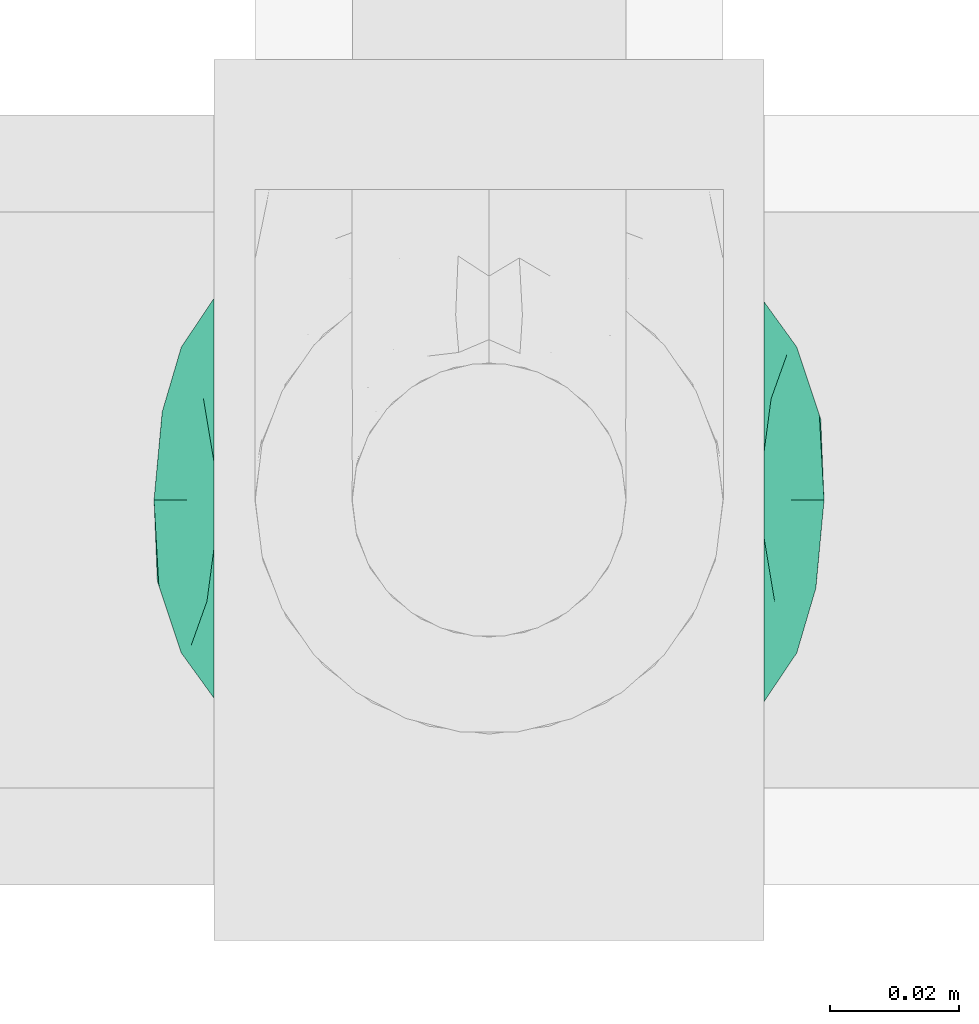
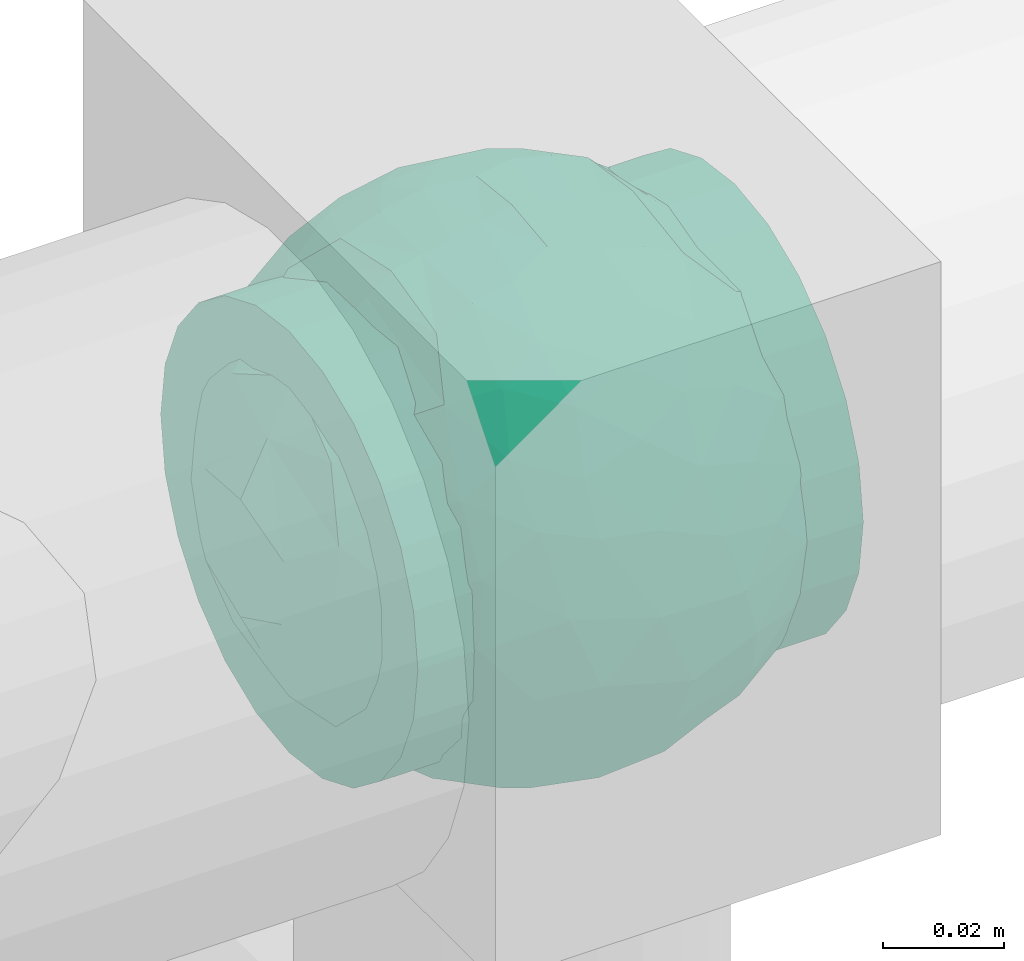
# One storey, part 572 of 827: 1 flow fitting.
"""IFC2X3 building model written with IfcOpenShell, lengths in millimetres."""

from ifc_helpers import new_model, entity, si_unit, converted_unit, derived_unit, direction, frame, origin, place, context, subcontext, project, spatial, faceted_brep, source, transform, mapped, material, material_list, type_object, type_shapes, element, save


model = new_model("IFC2X3")

# Units and contexts
model_context = context("Model", 3, precision=0.01, world=origin(), true_north=direction((6.12303176911189e-17, 1.0)))
body_context = subcontext(model_context, "Body", "Model", "MODEL_VIEW")
ifc_project = project(units=[si_unit("LENGTHUNIT", "METRE", prefix="MILLI"), si_unit("AREAUNIT", "SQUARE_METRE"), si_unit("VOLUMEUNIT", "CUBIC_METRE"), converted_unit("PLANEANGLEUNIT", "DEGREE", entity("IfcRatioMeasure", 0.0174532925199433), si_unit("PLANEANGLEUNIT", "RADIAN"), dimensions=[0, 0, 0, 0, 0, 0, 0]), si_unit("MASSUNIT", "GRAM", prefix="KILO"), derived_unit("MASSDENSITYUNIT", [(si_unit("MASSUNIT", "GRAM", prefix="KILO"), 1), (si_unit("LENGTHUNIT", "METRE"), -3)]), derived_unit("MOMENTOFINERTIAUNIT", [(si_unit("LENGTHUNIT", "METRE"), 4)]), si_unit("TIMEUNIT", "SECOND"), si_unit("FREQUENCYUNIT", "HERTZ"), si_unit("THERMODYNAMICTEMPERATUREUNIT", "DEGREE_CELSIUS"), derived_unit("THERMALTRANSMITTANCEUNIT", [(si_unit("MASSUNIT", "GRAM", prefix="KILO"), 1), (si_unit("THERMODYNAMICTEMPERATUREUNIT", "KELVIN"), -1), (si_unit("TIMEUNIT", "SECOND"), -3)]), derived_unit("VOLUMETRICFLOWRATEUNIT", [(si_unit("LENGTHUNIT", "METRE"), 3), (si_unit("TIMEUNIT", "SECOND"), -1)]), derived_unit("MASSFLOWRATEUNIT", [(si_unit("MASSUNIT", "GRAM", prefix="KILO"), 1), (si_unit("TIMEUNIT", "SECOND"), -1)]), derived_unit("ROTATIONALFREQUENCYUNIT", [(si_unit("TIMEUNIT", "SECOND"), -1)]), si_unit("ELECTRICCURRENTUNIT", "AMPERE"), si_unit("ELECTRICVOLTAGEUNIT", "VOLT"), si_unit("POWERUNIT", "WATT"), si_unit("FORCEUNIT", "NEWTON", prefix="KILO"), si_unit("ILLUMINANCEUNIT", "LUX"), si_unit("LUMINOUSFLUXUNIT", "LUMEN"), si_unit("LUMINOUSINTENSITYUNIT", "CANDELA"), derived_unit("USERDEFINED", [(si_unit("MASSUNIT", "GRAM", prefix="KILO"), -1), (si_unit("LENGTHUNIT", "METRE"), -2), (si_unit("TIMEUNIT", "SECOND"), 3), (si_unit("LUMINOUSFLUXUNIT", "LUMEN"), 1)]), derived_unit("LINEARVELOCITYUNIT", [(si_unit("LENGTHUNIT", "METRE"), 1), (si_unit("TIMEUNIT", "SECOND"), -1)]), si_unit("PRESSUREUNIT", "PASCAL"), derived_unit("USERDEFINED", [(si_unit("LENGTHUNIT", "METRE"), -2), (si_unit("MASSUNIT", "GRAM", prefix="KILO"), 1), (si_unit("TIMEUNIT", "SECOND"), -2)]), derived_unit("LINEARFORCEUNIT", [(si_unit("MASSUNIT", "GRAM", prefix="KILO"), 1), (si_unit("LENGTHUNIT", "METRE"), 1), (si_unit("TIMEUNIT", "SECOND"), -2), (si_unit("LENGTHUNIT", "METRE"), -1)]), derived_unit("PLANARFORCEUNIT", [(si_unit("MASSUNIT", "GRAM", prefix="KILO"), 1), (si_unit("LENGTHUNIT", "METRE"), 1), (si_unit("TIMEUNIT", "SECOND"), -2), (si_unit("LENGTHUNIT", "METRE"), -2)])], contexts=[model_context])

# Site, building, storey
site_placement = place(None, origin())
site = spatial("IfcSite", under=ifc_project, at=site_placement, CompositionType="ELEMENT")
building_placement = place(site_placement, origin())
building = spatial("IfcBuilding", under=site, at=building_placement, CompositionType="ELEMENT")
storey_placement = place(building_placement, frame((0.0, 0.0, 28200.0)))
storey = spatial("IfcBuildingStorey", under=building, at=storey_placement, Name="08", CompositionType="ELEMENT", Elevation=28200.0)

# Flow fitting
ifc_material_1 = material()
ifc_material_2 = material(Name="ADSK_")
ifc_material_list = material_list([ifc_material_1, ifc_material_2])
pipe_fitting_type = type_object("IfcPipeFittingType", Name="ADSK_1", PredefinedType="NOTDEFINED", material=ifc_material_list)
shared_shape = source(origin(), body_context, "Body", "Brep", [
    faceted_brep([(-42.5, 0.0, -42.5), (-42.5, -11.0, -41.05), (-42.5, -21.25, -36.81), (-42.5, -30.05, -30.05), (-42.5, -36.81, -21.25), (-42.5, -41.05, -11.0), (-42.5, -41.78, -5.5), (-42.5, -42.5, 0.0), (-42.5, -41.78, 5.5), (-42.5, -41.05, 11.0), (-42.5, -36.81, 21.25), (-42.5, -30.05, 30.05), (-42.5, -21.25, 36.81), (-42.5, -11.0, 41.05), (-42.5, 0.0, 42.5), (-42.5, 11.0, 41.05), (-42.5, 21.25, 36.81), (-42.5, 30.05, 30.05), (-42.5, 36.81, 21.25), (-42.5, 41.05, 11.0), (-42.5, 42.5, 0.0), (-42.5, 41.05, -11.0), (-42.5, 36.81, -21.25), (-42.5, 30.05, -30.05), (-42.5, 21.25, -36.81), (-42.5, 11.0, -41.05), (42.5, 11.0, -41.05), (42.5, 21.25, -36.81), (42.5, 30.05, -30.05), (42.5, 36.81, -21.25), (42.5, 41.05, -11.0), (42.5, 42.5, 0.0), (42.5, 41.05, 11.0), (42.5, 36.81, 21.25), (42.5, 30.05, 30.05), (42.5, 21.25, 36.81), (42.5, 11.0, 41.05), (42.5, 0.0, 42.5), (42.5, -11.0, 41.05), (42.5, -21.25, 36.81), (42.5, -30.05, 30.05), (42.5, -36.81, 21.25), (42.5, -41.05, 11.0), (42.5, -41.78, 5.5), (42.5, -42.5, 0.0), (42.5, -41.78, -5.5), (42.5, -41.05, -11.0), (42.5, -36.81, -21.25), (42.5, -30.05, -30.05), (42.5, -21.25, -36.81), (42.5, -11.0, -41.05), (42.5, 0.0, -42.5), (17.36, -42.02, 6.38), (18.5, -42.5, 0.0), (-18.5, -42.5, 0.0), (14.15, -40.8, 11.92), (3.25, -38.4, 18.21), (9.29, -39.37, 16.0), (6.27, -38.89, 17.11), (-17.36, -42.02, 6.38), (-17.93, -42.26, 3.19), (-14.16, -40.8, 11.91), (-9.29, -39.37, 16.0), (-6.27, -38.89, 17.1), (-3.25, -38.4, 18.21), (0.0, -38.4, 18.21), (17.93, -42.26, 3.19), (17.36, -42.02, -6.38), (3.25, -38.4, -18.21), (-17.36, -42.02, -6.38), (-17.93, -42.26, -3.19), (9.29, -39.37, -16.0), (6.27, -38.89, -17.11), (14.15, -40.8, -11.92), (17.93, -42.26, -3.19), (-3.25, -38.4, -18.21), (-6.27, -38.89, -17.1), (-9.29, -39.37, -16.0), (0.0, -38.4, -18.21), (-14.16, -40.8, -11.91), (17.87, -47.5, -4.79), (18.5, -47.5, 0.0), (17.87, -47.5, 4.79), (16.02, -47.5, 9.25), (13.08, -47.5, 13.08), (9.25, -47.5, 16.02), (4.79, -47.5, 17.87), (0.0, -47.5, 18.5), (-4.79, -47.5, 17.87), (-9.25, -47.5, 16.02), (-13.08, -47.5, 13.08), (-16.02, -47.5, 9.25), (-17.87, -47.5, 4.79), (-18.5, -47.5, 0.0), (-17.87, -47.5, -4.79), (-16.02, -47.5, -9.25), (-13.08, -47.5, -13.08), (-9.25, -47.5, -16.02), (-4.79, -47.5, -17.87), (0.0, -47.5, -18.5), (4.79, -47.5, -17.87), (9.25, -47.5, -16.02), (13.08, -47.5, -13.08), (16.02, -47.5, -9.25)], [[[0, 1, 2, 3, 4, 5, 6, 7, 8, 9, 10, 11, 12, 13, 14, 15, 16, 17, 18, 19, 20, 21, 22, 23, 24, 25]], [[26, 27, 28, 29, 30, 31, 32, 33, 34, 35, 36, 37, 38, 39, 40, 41, 42, 43, 44, 45, 46, 47, 48, 49, 50, 51]], [[43, 42, 52]], [[53, 44, 43]], [[7, 54, 8]], [[42, 55, 52]], [[41, 40, 56]], [[55, 42, 57]], [[41, 56, 58, 57]], [[40, 11, 56]], [[57, 42, 41]], [[59, 9, 8]], [[8, 54, 60, 59]], [[59, 61, 9]], [[10, 62, 63, 64]], [[10, 9, 62]], [[10, 64, 11]], [[62, 9, 61]], [[11, 64, 65, 56]], [[43, 52, 66, 53]], [[40, 39, 12, 11]], [[14, 13, 38, 37]], [[13, 12, 39, 38]], [[15, 14, 37, 36]], [[33, 32, 19, 18]], [[17, 16, 35, 34]], [[18, 17, 34, 33]], [[36, 35, 16, 15]], [[20, 19, 32, 31]], [[20, 31, 30, 21]], [[29, 28, 23, 22]], [[21, 30, 29, 22]], [[51, 50, 1, 0]], [[25, 24, 27, 26]], [[51, 0, 25, 26]], [[28, 27, 24, 23]], [[2, 1, 50, 49]], [[67, 46, 45]], [[49, 48, 3, 2]], [[48, 47, 68]], [[6, 69, 70, 54]], [[47, 71, 72, 68]], [[47, 46, 71]], [[48, 68, 3]], [[44, 53, 45]], [[6, 54, 7]], [[67, 73, 46]], [[45, 53, 74, 67]], [[46, 73, 71]], [[4, 75, 76, 77]], [[4, 3, 75]], [[77, 5, 4]], [[3, 68, 78, 75]], [[79, 69, 5]], [[69, 6, 5]], [[79, 5, 77]], [[80, 81, 82, 83, 84, 85, 86, 87, 88, 89, 90, 91, 92, 93, 94, 95, 96, 97, 98, 99, 100, 101, 102, 103]], [[92, 60, 93]], [[61, 91, 90]], [[92, 91, 59]], [[90, 89, 62]], [[92, 59, 60]], [[60, 54, 93]], [[59, 91, 61]], [[66, 52, 82]], [[88, 64, 63]], [[62, 61, 90]], [[87, 56, 65, 64]], [[85, 58, 86]], [[87, 64, 88]], [[56, 87, 86]], [[58, 85, 57]], [[55, 84, 83]], [[85, 84, 57]], [[52, 83, 82]], [[84, 55, 57]], [[56, 86, 58]], [[63, 62, 89]], [[81, 66, 82]], [[52, 55, 83]], [[66, 81, 53]], [[63, 89, 88]], [[80, 74, 81]], [[73, 103, 102]], [[80, 103, 67]], [[102, 101, 71]], [[80, 67, 74]], [[74, 53, 81]], [[67, 103, 73]], [[70, 69, 94]], [[100, 68, 72]], [[71, 73, 102]], [[99, 75, 78, 68]], [[97, 76, 98]], [[99, 68, 100]], [[75, 99, 98]], [[76, 97, 77]], [[79, 96, 95]], [[97, 96, 77]], [[69, 95, 94]], [[96, 79, 77]], [[75, 98, 76]], [[72, 71, 101]], [[93, 70, 94]], [[69, 79, 95]], [[70, 93, 54]], [[72, 101, 100]]]),
    faceted_brep([(46.38, -14.47, -21.49), (47.57, 0.0, -23.65), (51.28, -5.95, -12.54), (17.7, 5.66, -49.77), (12.28, -8.85, -50.92), (2.15, 2.87, -53.0), (-8.3, -38.19, -35.98), (-18.28, -40.66, -28.89), (-11.82, -29.03, -42.89), (40.06, -7.7, -34.03), (11.3, 28.17, -43.6), (20.41, 21.08, -44.28), (11.07, 18.92, -48.39), (51.79, 0.0, 0.0), (51.07, 6.92, -12.89), (-39.8, 12.92, -32.73), (-33.3, 12.91, -39.33), (-40.47, 3.74, -34.21), (51.79, 11.82, 0.0), (10.27, 45.23, -25.91), (18.57, 40.35, -29.15), (8.87, 37.57, -36.49), (39.0, 21.71, -28.82), (29.98, 13.37, -41.77), (30.17, 25.51, -35.52), (39.42, 8.24, -34.65), (32.29, 40.49, 0.0), (36.91, 36.81, 0.0), (35.0, 34.14, -20.79), (27.67, 44.18, 0.0), (-47.57, 0.0, -23.65), (-38.16, -9.26, -35.78), (-45.37, -12.95, -24.42), (5.76, -51.81, 0.0), (0.0, -51.83, -11.64), (8.06, -50.4, -14.75), (36.12, -33.63, -19.67), (42.51, -27.89, -15.42), (32.29, -40.49, 0.0), (-50.53, -9.19, -13.6), (46.66, -22.47, 0.0), (-50.52, 9.22, -13.61), (-46.66, 22.47, 0.0), (-44.16, 25.02, -15.71), (-39.0, 21.71, -28.82), (-45.35, 12.92, -24.47), (-0.05, -47.47, -23.85), (46.06, 13.95, -22.51), (-10.28, -45.49, -25.44), (3.12, -40.7, -34.0), (11.24, -34.38, -38.91), (18.57, -40.35, -29.15), (31.25, -15.19, -40.19), (31.09, 0.0, -43.08), (-36.91, 36.81, 0.0), (-37.82, 32.8, -17.79), (17.29, 49.18, 0.0), (16.36, 48.2, -15.2), (11.53, 50.49, 0.0), (-23.47, 44.9, -15.98), (-17.29, 49.18, 0.0), (-16.36, 48.2, -15.2), (-37.8, -32.81, -17.81), (-36.91, -36.81, 0.0), (-44.14, -25.04, -15.71), (-22.53, -31.78, -36.12), (-23.47, -44.9, -15.98), (-30.38, -38.01, -21.33), (29.72, -28.61, -33.48), (28.22, -39.05, -22.38), (-4.99, -13.62, -51.1), (-3.95, -23.43, -47.52), (0.0, -31.72, -42.62), (-9.33, 24.94, -45.97), (-11.38, 12.91, -50.26), (-20.38, 21.05, -44.31), (20.41, -21.08, -44.28), (10.92, -45.96, -24.31), (-17.29, -49.18, 0.0), (-16.38, -48.27, -14.96), (-11.53, -50.49, 0.0), (-23.05, -47.86, 0.0), (-27.67, -44.18, 0.0), (-32.29, -40.49, 0.0), (-28.59, -12.44, -43.01), (-30.36, -23.94, -36.43), (-15.25, 0.59, -50.89), (21.67, 31.55, -36.84), (27.5, 37.78, -25.27), (-2.02, 40.69, -34.1), (-0.05, 47.47, -23.85), (-10.14, 45.33, -25.77), (-10.75, 35.1, -38.4), (-18.28, 40.66, -28.89), (-30.38, 38.01, -21.33), (-32.29, 40.49, 0.0), (-27.67, 44.18, 0.0), (-23.05, 47.86, 0.0), (0.98, 18.06, -49.95), (0.0, 31.72, -42.62), (-30.21, 25.12, -35.76), (23.46, -45.39, -14.56), (0.0, -53.13, 0.0), (-8.48, 50.24, -15.03), (-11.53, 50.49, 0.0), (-5.76, 51.81, 0.0), (-41.53, -33.12, 0.0), (-39.0, -21.71, -28.82), (-21.3, 31.75, -36.88), (51.79, -11.82, 0.0), (39.0, -21.71, -28.82), (41.53, -33.12, 0.0), (46.66, 22.47, 0.0), (43.6, 26.01, -15.64), (22.77, -10.48, -46.84), (21.09, -32.2, -36.62), (27.67, -44.18, 0.0), (8.79, -24.03, -46.56), (-20.38, -21.05, -44.31), (-18.66, -10.27, -48.67), (-31.09, 0.0, -43.08), (-23.67, 8.98, -46.71), (23.05, -47.86, 0.0), (-8.24, -50.28, -15.03), (23.47, 45.01, -15.67), (23.05, 47.86, 0.0), (8.44, 50.21, -15.18), (5.76, 51.81, 0.0), (-46.66, -22.47, 0.0), (-41.53, 33.12, 0.0), (-51.79, 11.82, 0.0), (-51.79, -11.82, 0.0), (-51.79, 0.0, 0.0), (0.0, 53.12, 0.0), (0.0, 51.81, -11.73), (-5.76, -51.81, 0.0), (17.29, -49.18, 0.0), (11.53, -50.49, 0.0), (41.53, 33.12, 0.0), (36.91, -36.81, 0.0), (-46.38, -14.47, 21.49), (-47.57, 0.0, 23.65), (-51.28, -5.95, 12.54), (-17.7, 5.66, 49.77), (-12.28, -8.85, 50.92), (-2.15, 2.87, 53.0), (8.3, -38.19, 35.98), (18.28, -40.66, 28.89), (11.82, -29.03, 42.89), (-40.06, -7.7, 34.03), (-11.3, 28.17, 43.6), (-20.41, 21.08, 44.28), (-11.07, 18.92, 48.39), (-51.07, 6.92, 12.89), (39.8, 12.92, 32.73), (33.3, 12.91, 39.33), (40.47, 3.74, 34.21), (-10.27, 45.23, 25.91), (-18.57, 40.35, 29.15), (-8.87, 37.57, 36.49), (-39.0, 21.71, 28.82), (-29.98, 13.37, 41.77), (-30.17, 25.51, 35.52), (-39.42, 8.24, 34.65), (-35.0, 34.14, 20.79), (47.57, 0.0, 23.65), (38.16, -9.26, 35.78), (45.37, -12.95, 24.42), (0.0, -51.83, 11.64), (-8.06, -50.4, 14.75), (-36.12, -33.63, 19.67), (-42.51, -27.89, 15.42), (50.53, -9.19, 13.6), (50.52, 9.22, 13.61), (44.16, 25.02, 15.71), (39.0, 21.71, 28.82), (45.35, 12.92, 24.47), (0.05, -47.47, 23.85), (-46.06, 13.95, 22.51), (10.28, -45.49, 25.44), (-3.12, -40.7, 34.0), (-11.24, -34.38, 38.91), (-18.57, -40.35, 29.15), (-31.25, -15.19, 40.19), (-31.09, 0.0, 43.08), (37.82, 32.8, 17.79), (-16.36, 48.2, 15.2), (23.47, 44.9, 15.98), (16.36, 48.2, 15.2), (37.8, -32.81, 17.81), (44.14, -25.04, 15.71), (22.53, -31.78, 36.12), (23.47, -44.9, 15.98), (30.38, -38.01, 21.33), (-29.72, -28.61, 33.48), (-28.22, -39.05, 22.38), (4.99, -13.62, 51.1), (3.95, -23.43, 47.52), (0.0, -31.72, 42.62), (9.33, 24.94, 45.97), (11.38, 12.91, 50.26), (20.38, 21.05, 44.31), (-20.41, -21.08, 44.28), (-10.92, -45.96, 24.31), (16.38, -48.27, 14.96), (28.59, -12.44, 43.01), (30.36, -23.94, 36.43), (15.25, 0.59, 50.89), (-21.67, 31.55, 36.84), (-27.5, 37.78, 25.27), (2.02, 40.69, 34.1), (0.05, 47.47, 23.85), (10.14, 45.33, 25.77), (10.75, 35.1, 38.4), (18.28, 40.66, 28.89), (30.38, 38.01, 21.33), (-0.98, 18.06, 49.95), (0.0, 31.72, 42.62), (30.21, 25.12, 35.76), (-23.46, -45.39, 14.56), (8.48, 50.24, 15.03), (39.0, -21.71, 28.82), (21.3, 31.75, 36.88), (-39.0, -21.71, 28.82), (-43.6, 26.01, 15.64), (-22.77, -10.48, 46.84), (-21.09, -32.2, 36.62), (-8.79, -24.03, 46.56), (20.38, -21.05, 44.31), (18.66, -10.27, 48.67), (31.09, 0.0, 43.08), (23.67, 8.98, 46.71), (8.24, -50.28, 15.03), (-23.47, 45.01, 15.67), (-8.44, 50.21, 15.18), (0.0, 51.81, 11.73)], [[[0, 1, 2]], [[3, 4, 5]], [[6, 7, 8]], [[1, 0, 9]], [[10, 11, 12]], [[13, 2, 14]], [[15, 16, 17]], [[14, 18, 13]], [[19, 20, 21]], [[22, 23, 24]], [[1, 9, 25]], [[26, 27, 28, 29]], [[30, 31, 32]], [[33, 34, 35]], [[36, 37, 38]], [[32, 39, 30]], [[2, 40, 0]], [[23, 22, 25]], [[41, 42, 43]], [[44, 15, 45]], [[46, 35, 34]], [[25, 22, 47]], [[31, 30, 17]], [[48, 49, 46]], [[50, 51, 49]], [[52, 53, 9]], [[43, 54, 55]], [[56, 57, 58]], [[59, 60, 61]], [[62, 63, 64]], [[8, 7, 65]], [[7, 66, 67]], [[68, 36, 69]], [[70, 5, 4]], [[8, 71, 72]], [[73, 74, 75]], [[68, 76, 52]], [[77, 46, 49]], [[78, 79, 80]], [[7, 6, 48]], [[67, 81, 82, 83]], [[84, 85, 31]], [[85, 65, 67]], [[70, 86, 5]], [[23, 3, 11]], [[21, 87, 10]], [[21, 20, 87]], [[28, 24, 88]], [[19, 89, 90]], [[91, 90, 89]], [[91, 92, 93]], [[94, 95, 96, 97]], [[98, 99, 10]], [[100, 16, 44]], [[77, 51, 101]], [[33, 102, 34]], [[103, 91, 61]], [[93, 59, 61]], [[104, 105, 103]], [[106, 64, 63]], [[107, 31, 85]], [[100, 94, 108]], [[108, 93, 92]], [[43, 55, 44]], [[0, 40, 37]], [[2, 13, 109]], [[2, 1, 14]], [[110, 9, 0]], [[2, 109, 40]], [[37, 40, 111]], [[47, 14, 1]], [[112, 14, 47]], [[113, 112, 47]], [[112, 18, 14]], [[47, 22, 113]], [[52, 9, 110]], [[53, 25, 9]], [[25, 47, 1]], [[23, 25, 53]], [[68, 52, 110]], [[76, 4, 114]], [[51, 115, 69]], [[50, 115, 51]], [[110, 36, 68]], [[3, 23, 53]], [[23, 11, 24]], [[52, 76, 114]], [[98, 12, 5]], [[11, 87, 24]], [[24, 28, 22]], [[87, 88, 24]], [[36, 116, 69]], [[28, 27, 113]], [[114, 3, 53]], [[76, 115, 117]], [[70, 4, 117]], [[118, 84, 119]], [[119, 70, 118]], [[120, 16, 121]], [[37, 36, 110]], [[116, 36, 38]], [[116, 122, 69]], [[34, 123, 46]], [[10, 87, 11]], [[87, 20, 88]], [[12, 98, 10]], [[10, 99, 21]], [[74, 5, 86]], [[73, 75, 108]], [[124, 56, 125]], [[124, 29, 88]], [[89, 21, 99]], [[21, 89, 19]], [[92, 89, 99]], [[89, 92, 91]], [[126, 127, 58]], [[88, 29, 28]], [[20, 57, 124]], [[88, 20, 124]], [[57, 20, 19]], [[73, 92, 99]], [[92, 73, 108]], [[99, 98, 73]], [[74, 86, 121]], [[73, 98, 74]], [[5, 74, 98]], [[100, 108, 75]], [[94, 93, 108]], [[86, 120, 121]], [[100, 44, 55]], [[75, 16, 100]], [[17, 16, 120]], [[31, 17, 120]], [[17, 30, 45]], [[84, 31, 120]], [[31, 107, 32]], [[41, 45, 30]], [[43, 44, 45]], [[107, 64, 32]], [[39, 64, 128]], [[30, 39, 41]], [[129, 43, 42]], [[41, 130, 42]], [[43, 45, 41]], [[62, 83, 63]], [[95, 94, 55]], [[100, 55, 94]], [[64, 107, 62]], [[131, 39, 128]], [[64, 106, 128]], [[85, 62, 107]], [[67, 83, 62]], [[39, 32, 64]], [[130, 41, 132]], [[59, 97, 60]], [[133, 127, 134]], [[59, 94, 97]], [[104, 61, 60]], [[94, 59, 93]], [[126, 134, 127]], [[126, 58, 57]], [[19, 90, 126]], [[134, 105, 133]], [[126, 90, 134]], [[103, 90, 91]], [[105, 134, 103]], [[90, 103, 134]], [[119, 120, 86]], [[84, 118, 85]], [[65, 85, 118]], [[62, 85, 67]], [[8, 65, 118]], [[67, 65, 7]], [[71, 118, 70]], [[8, 72, 6]], [[49, 6, 72]], [[6, 49, 48]], [[50, 49, 72]], [[77, 49, 51]], [[101, 69, 122]], [[123, 34, 135]], [[101, 122, 136]], [[137, 77, 136]], [[78, 81, 66]], [[7, 79, 66]], [[67, 66, 81]], [[79, 7, 48]], [[35, 137, 33]], [[123, 80, 79]], [[135, 34, 102]], [[35, 46, 77]], [[80, 123, 135]], [[46, 123, 48]], [[117, 50, 72]], [[115, 76, 68]], [[117, 72, 71]], [[4, 76, 117]], [[39, 132, 41]], [[39, 131, 132]], [[137, 35, 77]], [[124, 57, 56]], [[126, 57, 19]], [[103, 61, 104]], [[61, 91, 93]], [[77, 101, 136]], [[51, 69, 101]], [[28, 113, 22]], [[112, 113, 138]], [[16, 75, 121]], [[74, 121, 75]], [[66, 79, 78]], [[123, 79, 48]], [[0, 37, 110]], [[37, 111, 139, 38]], [[29, 124, 125]], [[115, 50, 117]], [[69, 115, 68]], [[120, 119, 84]], [[70, 119, 86]], [[11, 3, 12]], [[5, 12, 3]], [[118, 71, 8]], [[117, 71, 70]], [[3, 114, 4]], [[53, 52, 114]], [[27, 138, 113]], [[45, 15, 17]], [[44, 16, 15]], [[55, 54, 95]], [[43, 129, 54]], [[140, 141, 142]], [[143, 144, 145]], [[146, 147, 148]], [[141, 140, 149]], [[150, 151, 152]], [[132, 142, 153]], [[154, 155, 156]], [[153, 130, 132]], [[157, 158, 159]], [[160, 161, 162]], [[141, 149, 163]], [[95, 54, 164, 96]], [[165, 166, 167]], [[135, 168, 169]], [[170, 171, 83]], [[167, 172, 165]], [[142, 128, 140]], [[161, 160, 163]], [[173, 112, 174]], [[175, 154, 176]], [[177, 169, 168]], [[163, 160, 178]], [[166, 165, 156]], [[179, 180, 177]], [[181, 182, 180]], [[183, 184, 149]], [[174, 27, 185]], [[60, 186, 104]], [[187, 56, 188]], [[189, 139, 190]], [[148, 147, 191]], [[147, 192, 193]], [[194, 170, 195]], [[196, 145, 144]], [[148, 197, 198]], [[199, 200, 201]], [[194, 202, 183]], [[203, 177, 180]], [[136, 204, 137]], [[147, 146, 179]], [[193, 122, 116, 38]], [[205, 206, 166]], [[206, 191, 193]], [[196, 207, 145]], [[161, 143, 151]], [[159, 208, 150]], [[159, 158, 208]], [[164, 162, 209]], [[157, 210, 211]], [[212, 211, 210]], [[212, 213, 214]], [[215, 26, 29, 125]], [[216, 217, 150]], [[218, 155, 175]], [[203, 182, 219]], [[135, 102, 168]], [[220, 212, 188]], [[214, 187, 188]], [[58, 127, 220]], [[111, 190, 139]], [[221, 166, 206]], [[218, 215, 222]], [[222, 214, 213]], [[174, 185, 175]], [[140, 128, 171]], [[142, 132, 131]], [[142, 141, 153]], [[223, 149, 140]], [[142, 131, 128]], [[171, 128, 106]], [[178, 153, 141]], [[42, 153, 178]], [[224, 42, 178]], [[42, 130, 153]], [[178, 160, 224]], [[183, 149, 223]], [[184, 163, 149]], [[163, 178, 141]], [[161, 163, 184]], [[194, 183, 223]], [[202, 144, 225]], [[182, 226, 195]], [[181, 226, 182]], [[223, 170, 194]], [[143, 161, 184]], [[161, 151, 162]], [[183, 202, 225]], [[216, 152, 145]], [[151, 208, 162]], [[162, 164, 160]], [[208, 209, 162]], [[170, 82, 195]], [[164, 54, 224]], [[225, 143, 184]], [[202, 226, 227]], [[196, 144, 227]], [[228, 205, 229]], [[229, 196, 228]], [[230, 155, 231]], [[171, 170, 223]], [[82, 170, 83]], [[82, 81, 195]], [[168, 232, 177]], [[150, 208, 151]], [[208, 158, 209]], [[152, 216, 150]], [[150, 217, 159]], [[200, 145, 207]], [[199, 201, 222]], [[233, 60, 97]], [[233, 96, 209]], [[210, 159, 217]], [[159, 210, 157]], [[213, 210, 217]], [[210, 213, 212]], [[234, 105, 104]], [[209, 96, 164]], [[158, 186, 233]], [[209, 158, 233]], [[186, 158, 157]], [[199, 213, 217]], [[213, 199, 222]], [[217, 216, 199]], [[200, 207, 231]], [[199, 216, 200]], [[145, 200, 216]], [[218, 222, 201]], [[215, 214, 222]], [[207, 230, 231]], [[218, 175, 185]], [[201, 155, 218]], [[156, 155, 230]], [[166, 156, 230]], [[156, 165, 176]], [[205, 166, 230]], [[166, 221, 167]], [[173, 176, 165]], [[174, 175, 176]], [[221, 190, 167]], [[172, 190, 40]], [[165, 172, 173]], [[138, 174, 112]], [[173, 18, 112]], [[174, 176, 173]], [[189, 38, 139]], [[26, 215, 185]], [[218, 185, 215]], [[190, 221, 189]], [[109, 172, 40]], [[190, 111, 40]], [[206, 189, 221]], [[193, 38, 189]], [[172, 167, 190]], [[18, 173, 13]], [[187, 125, 56]], [[133, 105, 235]], [[187, 215, 125]], [[58, 188, 56]], [[215, 187, 214]], [[234, 235, 105]], [[234, 104, 186]], [[157, 211, 234]], [[235, 127, 133]], [[234, 211, 235]], [[220, 211, 212]], [[127, 235, 220]], [[211, 220, 235]], [[229, 230, 207]], [[205, 228, 206]], [[191, 206, 228]], [[189, 206, 193]], [[148, 191, 228]], [[193, 191, 147]], [[197, 228, 196]], [[148, 198, 146]], [[180, 146, 198]], [[146, 180, 179]], [[181, 180, 198]], [[203, 180, 182]], [[219, 195, 81]], [[232, 168, 33]], [[219, 81, 78]], [[80, 203, 78]], [[136, 122, 192]], [[147, 204, 192]], [[193, 192, 122]], [[204, 147, 179]], [[169, 80, 135]], [[232, 137, 204]], [[33, 168, 102]], [[169, 177, 203]], [[137, 232, 33]], [[177, 232, 179]], [[227, 181, 198]], [[226, 202, 194]], [[227, 198, 197]], [[144, 202, 227]], [[172, 13, 173]], [[172, 109, 13]], [[80, 169, 203]], [[233, 186, 60]], [[234, 186, 157]], [[220, 188, 58]], [[188, 212, 214]], [[203, 219, 78]], [[182, 195, 219]], [[164, 224, 160]], [[42, 224, 129]], [[155, 201, 231]], [[200, 231, 201]], [[192, 204, 136]], [[232, 204, 179]], [[140, 171, 223]], [[171, 106, 63, 83]], [[96, 233, 97]], [[226, 181, 227]], [[195, 226, 194]], [[230, 229, 205]], [[196, 229, 207]], [[151, 143, 152]], [[145, 152, 143]], [[228, 197, 148]], [[227, 197, 196]], [[143, 225, 144]], [[184, 183, 225]], [[54, 129, 224]], [[176, 154, 156]], [[175, 155, 154]], [[185, 27, 26]], [[174, 138, 27]]]),
])
type_shapes(pipe_fitting_type, [shared_shape])
flow_fitting_placement = place(storey_placement, frame((17068.36, 14749.79, 2800.0), z_axis=(0.0, -1.0, 0.0), x_axis=(1.0, 0.0, 0.0)))
element("IfcFlowFitting", 1, at=flow_fitting_placement, inside=storey, type_object=pipe_fitting_type, material=ifc_material_list, Name="ADSK_1", ObjectType="ADSK_1", context=body_context, shape_type="MappedRepresentation", body=[
    mapped(shared_shape, transform((0.0, 0.0, 0.0), scale=1.0)),
])

save(model, "model.ifc")
